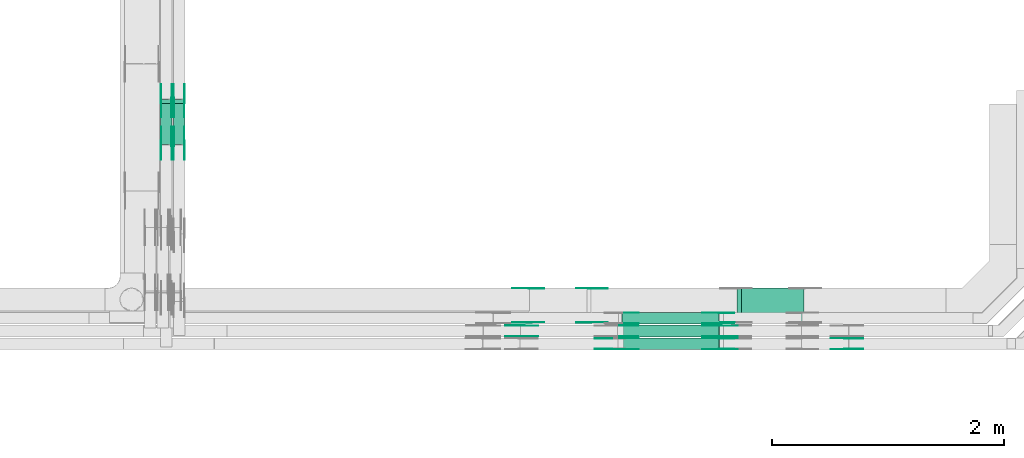
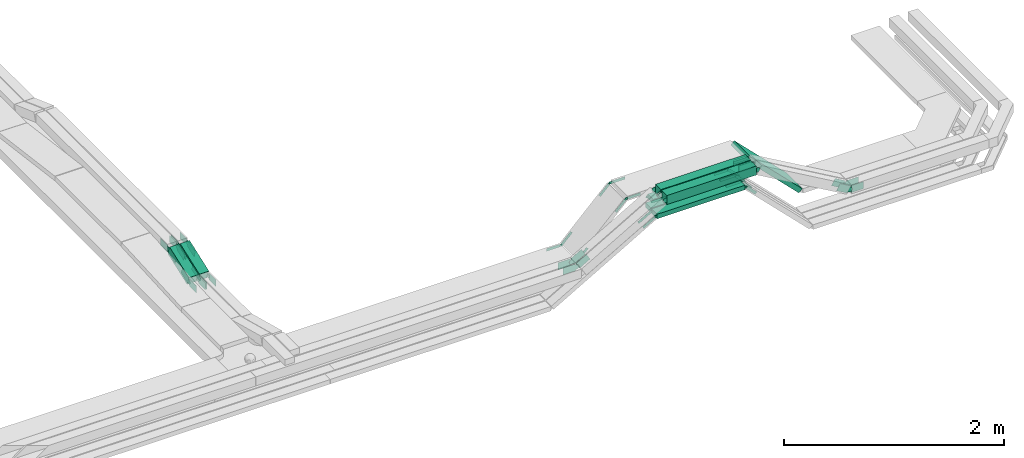
# One storey, part 26 of 32: 58 flow fittings, 8 flow segments.
"""IFC2X3 building model written with IfcOpenShell, lengths in millimetres."""

from ifc_helpers import new_model, entity, si_unit, converted_unit, derived_unit, direction, frame, frame_2d, origin, origin_2d_with_axis, place, context, subcontext, project, spatial, polyline, circle_curve, parameter, trimmed, segment, composite_curve, rectangle, outline, extrude, source, transform, mapped, material, type_object, type_shapes, element, save


model = new_model("IFC2X3")

# Units and contexts
model_context = context("Model", 3, precision=0.01, world=origin(), true_north=direction((6.12303176911189e-17, 1.0)))
body_context = subcontext(model_context, "Body", "Model", "MODEL_VIEW")
ifc_project = project(units=[si_unit("LENGTHUNIT", "METRE", prefix="MILLI"), si_unit("AREAUNIT", "SQUARE_METRE"), si_unit("VOLUMEUNIT", "CUBIC_METRE"), converted_unit("PLANEANGLEUNIT", "DEGREE", entity("IfcRatioMeasure", 0.0174532925199433), si_unit("PLANEANGLEUNIT", "RADIAN"), dimensions=[0, 0, 0, 0, 0, 0, 0]), si_unit("MASSUNIT", "GRAM", prefix="KILO"), derived_unit("MASSDENSITYUNIT", [(si_unit("MASSUNIT", "GRAM", prefix="KILO"), 1), (si_unit("LENGTHUNIT", "METRE"), -3)]), derived_unit("MOMENTOFINERTIAUNIT", [(si_unit("LENGTHUNIT", "METRE"), 4)]), si_unit("TIMEUNIT", "SECOND"), si_unit("FREQUENCYUNIT", "HERTZ"), si_unit("THERMODYNAMICTEMPERATUREUNIT", "DEGREE_CELSIUS"), derived_unit("THERMALTRANSMITTANCEUNIT", [(si_unit("MASSUNIT", "GRAM", prefix="KILO"), 1), (si_unit("THERMODYNAMICTEMPERATUREUNIT", "KELVIN"), -1), (si_unit("TIMEUNIT", "SECOND"), -3)]), derived_unit("VOLUMETRICFLOWRATEUNIT", [(si_unit("LENGTHUNIT", "METRE"), 3), (si_unit("TIMEUNIT", "SECOND"), -1)]), derived_unit("MASSFLOWRATEUNIT", [(si_unit("MASSUNIT", "GRAM", prefix="KILO"), 1), (si_unit("TIMEUNIT", "SECOND"), -1)]), derived_unit("ROTATIONALFREQUENCYUNIT", [(si_unit("TIMEUNIT", "SECOND"), -1)]), si_unit("ELECTRICCURRENTUNIT", "AMPERE"), si_unit("ELECTRICVOLTAGEUNIT", "VOLT"), si_unit("POWERUNIT", "WATT"), si_unit("FORCEUNIT", "NEWTON", prefix="KILO"), si_unit("ILLUMINANCEUNIT", "LUX"), si_unit("LUMINOUSFLUXUNIT", "LUMEN"), si_unit("LUMINOUSINTENSITYUNIT", "CANDELA"), derived_unit("USERDEFINED", [(si_unit("MASSUNIT", "GRAM", prefix="KILO"), -1), (si_unit("LENGTHUNIT", "METRE"), -2), (si_unit("TIMEUNIT", "SECOND"), 3), (si_unit("LUMINOUSFLUXUNIT", "LUMEN"), 1)]), derived_unit("LINEARVELOCITYUNIT", [(si_unit("LENGTHUNIT", "METRE"), 1), (si_unit("TIMEUNIT", "SECOND"), -1)]), si_unit("PRESSUREUNIT", "PASCAL"), derived_unit("USERDEFINED", [(si_unit("LENGTHUNIT", "METRE"), -2), (si_unit("MASSUNIT", "GRAM", prefix="KILO"), 1), (si_unit("TIMEUNIT", "SECOND"), -2)]), derived_unit("LINEARFORCEUNIT", [(si_unit("MASSUNIT", "GRAM", prefix="KILO"), 1), (si_unit("LENGTHUNIT", "METRE"), 1), (si_unit("TIMEUNIT", "SECOND"), -2), (si_unit("LENGTHUNIT", "METRE"), -1)]), derived_unit("PLANARFORCEUNIT", [(si_unit("MASSUNIT", "GRAM", prefix="KILO"), 1), (si_unit("LENGTHUNIT", "METRE"), 1), (si_unit("TIMEUNIT", "SECOND"), -2), (si_unit("LENGTHUNIT", "METRE"), -2)])], contexts=[model_context])

# Site, building, storey
site_placement = place(None, origin())
site = spatial("IfcSite", under=ifc_project, at=site_placement, CompositionType="ELEMENT")
building_placement = place(site_placement, origin())
building = spatial("IfcBuilding", under=site, at=building_placement, CompositionType="ELEMENT")
storey_placement = place(building_placement, frame((0.0, 0.0, 8100.0)))
storey = spatial("IfcBuildingStorey", under=building, at=storey_placement, CompositionType="ELEMENT", Elevation=8100.0)

# Flow segments
cable_carrier_segment_type = type_object("IfcCableCarrierSegmentType", PredefinedType="CABLETRAYSEGMENT")
flow_segment_1_placement = place(storey_placement, frame((64598.66, 8749.98, 3299.35)))
element("IfcFlowSegment", 1, at=flow_segment_1_placement, inside=storey, type_object=cable_carrier_segment_type, context=body_context, shape_type="SweptSolid", body=[
    extrude(rectangle(XDim=939.968624882914, YDim=99.9999999999989, at=origin_2d_with_axis()), frame((469.98, 50.0, 0.0)), (0.0, 0.0, 1.0), 99.9999999999989),
])
flow_segment_2_placement = place(storey_placement, frame((65573.52, 8869.98, 2758.52)))
element("IfcFlowSegment", 2, at=flow_segment_2_placement, inside=storey, type_object=cable_carrier_segment_type, context=body_context, shape_type="SweptSolid", body=[
    extrude(rectangle(XDim=49.9999999999911, YDim=299.999999999999, at=frame_2d((0.0, 0.0), x_axis=(0.0, 1.0))), frame((17.68, 150.0, 559.42), z_axis=(0.707106781186569, 0.0, -0.707106781186526), x_axis=(0.0, 1.0, 0.0)), (0.0, 0.0, 1.0), 766.14487381345),
])
flow_segment_3_placement = place(storey_placement, frame((64600.05, 8639.98, 3300.15)))
element("IfcFlowSegment", 3, at=flow_segment_3_placement, inside=storey, type_object=cable_carrier_segment_type, context=body_context, shape_type="SweptSolid", body=[
    extrude(rectangle(XDim=937.197353006379, YDim=100.000000000001, at=origin_2d_with_axis()), frame((468.6, 50.0, 0.0), z_axis=(0.0, 0.0, 1.0), x_axis=(-1.0, 0.0, 0.0)), (0.0, 0.0, 1.0), 99.9999999999989),
])
flow_segment_4_placement = place(storey_placement, frame((64494.58, 8639.98, 3179.57)))
element("IfcFlowSegment", 4, at=flow_segment_4_placement, inside=storey, type_object=cable_carrier_segment_type, context=body_context, shape_type="SweptSolid", body=[
    extrude(rectangle(XDim=920.492323280355, YDim=99.9999999979415, at=origin_2d_with_axis()), frame((460.25, 50.0, 0.0), z_axis=(-6.41725804195765e-06, 0.0, 1.0), x_axis=(-1.0, 0.0, -6.41725804195765e-06)), (0.0, 0.0, 1.0), 49.9999999989737),
])
flow_segment_5_placement = place(storey_placement, frame((64494.58, 8749.98, 3179.57)))
element("IfcFlowSegment", 5, at=flow_segment_5_placement, inside=storey, type_object=cable_carrier_segment_type, context=body_context, shape_type="SweptSolid", body=[
    extrude(rectangle(XDim=920.463298114925, YDim=99.9999999758575, at=origin_2d_with_axis()), frame((460.23, 50.0, 0.01), z_axis=(-3.05650475309181e-05, 0.0, 1.0), x_axis=(-1.0, 0.0, -3.05650475309181e-05)), (0.0, 0.0, 1.0), 49.9999999879301),
])
flow_segment_6_placement = place(storey_placement, frame((64581.24, 8859.98, 3179.57)))
element("IfcFlowSegment", 6, at=flow_segment_6_placement, inside=storey, type_object=cable_carrier_segment_type, context=body_context, shape_type="SweptSolid", body=[
    extrude(rectangle(XDim=833.83326858157, YDim=100.000000000001, at=origin_2d_with_axis()), frame((416.92, 50.0, 0.0), z_axis=(0.0, 0.0, 1.0), x_axis=(-1.0, 0.0, 0.0)), (0.0, 0.0, 1.0), 50.0000000000016),
])
flow_segment_7_placement = place(storey_placement, frame((60610.11, 10406.15, 2721.68)))
element("IfcFlowSegment", 7, at=flow_segment_7_placement, inside=storey, type_object=cable_carrier_segment_type, context=body_context, shape_type="SweptSolid", body=[
    extrude(rectangle(XDim=100.000000000001, YDim=99.9999999999946, at=origin_2d_with_axis()), frame((50.0, 17.1, 46.98), z_axis=(0.0, 0.939692620785929, 0.342020143325613), x_axis=(0.0, -0.342020143325613, 0.939692620785929)), (0.0, 0.0, 1.0), 373.670280105796),
])
flow_segment_8_placement = place(storey_placement, frame((60720.11, 10406.13, 2721.71)))
element("IfcFlowSegment", 8, at=flow_segment_8_placement, inside=storey, type_object=cable_carrier_segment_type, context=body_context, shape_type="SweptSolid", body=[
    extrude(rectangle(XDim=99.9999999999992, YDim=99.9999999999946, at=origin_2d_with_axis()), frame((50.0, 17.1, 46.98), z_axis=(0.0, 0.939692620787677, 0.34202014332081), x_axis=(0.0, -0.34202014332081, 0.939692620787677)), (0.0, 0.0, 1.0), 373.682611233208),
])

# Flow fittings
ifc_material = material(Name="G")
cable_carrier_fitting_type_1 = type_object("IfcCableCarrierFittingType", PredefinedType="NOTDEFINED", material=ifc_material)
shared_shape_1 = source(origin(), body_context, "Body", "SweptSolid", [
    extrude(outline(composite_curve([segment(trimmed(circle_curve(frame_2d((-44.59, 0.0), x_axis=(1.0, 0.0)), 12.5), [parameter(90.0000000000007)], [parameter(270.0)], True, "PARAMETER"), True, "CONTINUOUS"), segment(polyline([(-44.59, -12.5), (-33.09, -12.5)]), True, "CONTINUOUS"), segment(polyline([(-33.09, -12.5), (-31.23, -14.5)]), True, "CONTINUOUS"), segment(polyline([(-31.23, -14.5), (108.91, -14.5)]), True, "CONTINUOUS"), segment(polyline([(108.91, -14.5), (108.91, 14.5)]), True, "CONTINUOUS"), segment(polyline([(108.91, 14.5), (-31.23, 14.5)]), True, "CONTINUOUS"), segment(polyline([(-31.23, 14.5), (-33.09, 12.5)]), True, "CONTINUOUS"), segment(polyline([(-33.09, 12.5), (-44.59, 12.5)]), True, "CONTINUOUS")], self_intersect=False)), frame((44.59, 0.0, 0.0), z_axis=(0.0, 0.0, -1.0), x_axis=(1.0, 0.0, 0.0)), (0.0, 0.0, -1.0), 2.0),
])
type_shapes(cable_carrier_fitting_type_1, [shared_shape_1])
flow_fitting_1_placement = place(storey_placement, frame((65428.08, 8864.52, 3204.57), z_axis=(0.0, -1.0, 0.0), x_axis=(-1.0, 0.0, 0.0)))
element("IfcFlowFitting", 9, at=flow_fitting_1_placement, inside=storey, type_object=cable_carrier_fitting_type_1, material=ifc_material, context=body_context, shape_type="MappedRepresentation", body=[
    mapped(shared_shape_1, transform((0.0, 0.0, 0.0), scale=1.0)),
])
cable_carrier_fitting_type_2 = type_object("IfcCableCarrierFittingType", PredefinedType="NOTDEFINED", material=ifc_material)
type_shapes(cable_carrier_fitting_type_2, [shared_shape_1])
flow_fitting_2_placement = place(storey_placement, frame((65428.08, 8953.44, 3204.57), z_axis=(0.0, 1.0, 0.0), x_axis=(0.707106781186533, 0.0, -0.707106781186562)))
element("IfcFlowFitting", 10, at=flow_fitting_2_placement, inside=storey, type_object=cable_carrier_fitting_type_2, material=ifc_material, context=body_context, shape_type="MappedRepresentation", body=[
    mapped(shared_shape_1, transform((0.0, 0.0, 0.0), scale=1.0)),
])
for number, where, z_axis, x_axis in (
    (11, (64572.47, 8955.44, 3204.57), (0.0, 1.0, 0.0), (1.0, 0.0, 0.0)),
    (12, (65428.06, 8754.52, 3204.6), (0.0, -1.0, 0.0), (-0.999999977631966, 0.0, -0.000211509025242751)),
):
    element("IfcFlowFitting", number, at=place(storey_placement, frame(where, z_axis=z_axis, x_axis=x_axis)), inside=storey, type_object=cable_carrier_fitting_type_1, material=ifc_material, context=body_context, shape_type="MappedRepresentation", body=[
        mapped(shared_shape_1, transform((0.0, 0.0, 0.0), scale=1.0)),
    ])
flow_fitting_3_placement = place(storey_placement, frame((65428.06, 8843.44, 3204.6), z_axis=(0.0, 1.0, 0.0), x_axis=(0.707106781186527, 0.0, -0.707106781186568)))
element("IfcFlowFitting", 13, at=flow_fitting_3_placement, inside=storey, type_object=cable_carrier_fitting_type_2, material=ifc_material, context=body_context, shape_type="MappedRepresentation", body=[
    mapped(shared_shape_1, transform((0.0, 0.0, 0.0), scale=1.0)),
])
flow_fitting_4_placement = place(storey_placement, frame((65428.08, 8644.52, 3204.57), z_axis=(0.0, -1.0, 0.0), x_axis=(-1.0, 0.0, -2.81226541815616e-05)))
element("IfcFlowFitting", 14, at=flow_fitting_4_placement, inside=storey, type_object=cable_carrier_fitting_type_1, material=ifc_material, context=body_context, shape_type="MappedRepresentation", body=[
    mapped(shared_shape_1, transform((0.0, 0.0, 0.0), scale=1.0)),
])
for number, where, z_axis, x_axis in (
    (15, (65428.08, 8733.44, 3204.57), (0.0, 1.0, 0.0), (0.707106781186496, 0.0, -0.707106781186599)),
    (16, (64485.81, 8646.52, 3204.57), (0.0, -1.0, 0.0), (-0.866025403784408, 0.0, -0.500000000000054)),
):
    element("IfcFlowFitting", number, at=place(storey_placement, frame(where, z_axis=z_axis, x_axis=x_axis)), inside=storey, type_object=cable_carrier_fitting_type_2, material=ifc_material, context=body_context, shape_type="MappedRepresentation", body=[
        mapped(shared_shape_1, transform((0.0, 0.0, 0.0), scale=1.0)),
    ])
flow_fitting_5_placement = place(storey_placement, frame((64306.08, 8874.52, 3327.15), z_axis=(0.0, -1.0, 0.0), x_axis=(-0.707106781186591, 0.0, -0.707106781186504)))
element("IfcFlowFitting", 17, at=flow_fitting_5_placement, inside=storey, type_object=cable_carrier_fitting_type_1, material=ifc_material, context=body_context, shape_type="MappedRepresentation", body=[
    mapped(shared_shape_1, transform((0.0, 0.0, 0.0), scale=1.0)),
])
for number, where, z_axis, x_axis in (
    (18, (64306.08, 9163.44, 3327.15), (0.0, 1.0, 0.0), (1.0, 0.0, 0.0)),
    (19, (65581.99, 8876.52, 3327.15), (0.0, -1.0, 0.0), (-1.0, 0.0, 0.0)),
):
    element("IfcFlowFitting", number, at=place(storey_placement, frame(where, z_axis=z_axis, x_axis=x_axis)), inside=storey, type_object=cable_carrier_fitting_type_2, material=ifc_material, context=body_context, shape_type="MappedRepresentation", body=[
        mapped(shared_shape_1, transform((0.0, 0.0, 0.0), scale=1.0)),
    ])
flow_fitting_6_placement = place(storey_placement, frame((63792.86, 9165.44, 2813.92), z_axis=(0.0, 1.0, 0.0), x_axis=(-1.0, 0.0, 0.0)))
element("IfcFlowFitting", 20, at=flow_fitting_6_placement, inside=storey, type_object=cable_carrier_fitting_type_1, material=ifc_material, context=body_context, shape_type="MappedRepresentation", body=[
    mapped(shared_shape_1, transform((0.0, 0.0, 0.0), scale=1.0)),
])
flow_fitting_7_placement = place(storey_placement, frame((63792.86, 8876.52, 2813.92), z_axis=(0.0, -1.0, 0.0), x_axis=(0.70710678118647, 0.0, 0.707106781186625)))
element("IfcFlowFitting", 21, at=flow_fitting_7_placement, inside=storey, type_object=cable_carrier_fitting_type_2, material=ifc_material, context=body_context, shape_type="MappedRepresentation", body=[
    mapped(shared_shape_1, transform((0.0, 0.0, 0.0), scale=1.0)),
])
cable_carrier_fitting_type_3 = type_object("IfcCableCarrierFittingType", PredefinedType="NOTDEFINED", material=ifc_material)
shared_shape_2 = source(origin(), body_context, "Body", "SweptSolid", [
    extrude(outline(composite_curve([segment(trimmed(circle_curve(frame_2d((-44.59, 0.0), x_axis=(1.0, 0.0)), 12.5), [parameter(90.0000000000007)], [parameter(270.0)], True, "PARAMETER"), True, "CONTINUOUS"), segment(polyline([(-44.59, -12.5), (-33.09, -12.5)]), True, "CONTINUOUS"), segment(polyline([(-33.09, -12.5), (-31.23, -14.5)]), True, "CONTINUOUS"), segment(polyline([(-31.23, -14.5), (108.91, -14.5)]), True, "CONTINUOUS"), segment(polyline([(108.91, -14.5), (108.91, 14.5)]), True, "CONTINUOUS"), segment(polyline([(108.91, 14.5), (-31.23, 14.5)]), True, "CONTINUOUS"), segment(polyline([(-31.23, 14.5), (-33.09, 12.5)]), True, "CONTINUOUS"), segment(polyline([(-33.09, 12.5), (-44.59, 12.5)]), True, "CONTINUOUS")], self_intersect=False)), frame((44.59, 0.0, 0.0)), (0.0, 0.0, 1.0), 2.0),
])
type_shapes(cable_carrier_fitting_type_3, [shared_shape_2])
flow_fitting_8_placement = place(storey_placement, frame((65428.08, 8955.44, 3204.57), z_axis=(0.0, 1.0, 0.0), x_axis=(-1.0, 0.0, 0.0)))
element("IfcFlowFitting", 22, at=flow_fitting_8_placement, inside=storey, type_object=cable_carrier_fitting_type_3, material=ifc_material, context=body_context, shape_type="MappedRepresentation", body=[
    mapped(shared_shape_2, transform((0.0, 0.0, 0.0), scale=1.0)),
])
cable_carrier_fitting_type_4 = type_object("IfcCableCarrierFittingType", PredefinedType="NOTDEFINED", material=ifc_material)
type_shapes(cable_carrier_fitting_type_4, [shared_shape_2])
flow_fitting_9_placement = place(storey_placement, frame((65428.08, 8866.52, 3204.57), z_axis=(0.0, -1.0, 0.0), x_axis=(0.707106781186533, 0.0, -0.707106781186562)))
element("IfcFlowFitting", 23, at=flow_fitting_9_placement, inside=storey, type_object=cable_carrier_fitting_type_4, material=ifc_material, context=body_context, shape_type="MappedRepresentation", body=[
    mapped(shared_shape_2, transform((0.0, 0.0, 0.0), scale=1.0)),
])
for number, where, z_axis, x_axis in (
    (24, (64572.47, 8864.52, 3204.57), (0.0, -1.0, 0.0), (1.0, 0.0, 0.0)),
    (25, (65428.06, 8845.44, 3204.6), (0.0, 1.0, 0.0), (-0.999999977631966, 0.0, -0.000211509025242751)),
):
    element("IfcFlowFitting", number, at=place(storey_placement, frame(where, z_axis=z_axis, x_axis=x_axis)), inside=storey, type_object=cable_carrier_fitting_type_3, material=ifc_material, context=body_context, shape_type="MappedRepresentation", body=[
        mapped(shared_shape_2, transform((0.0, 0.0, 0.0), scale=1.0)),
    ])
flow_fitting_10_placement = place(storey_placement, frame((65428.06, 8756.52, 3204.6), z_axis=(0.0, -1.0, 0.0), x_axis=(0.707106781186527, 0.0, -0.707106781186568)))
element("IfcFlowFitting", 26, at=flow_fitting_10_placement, inside=storey, type_object=cable_carrier_fitting_type_4, material=ifc_material, context=body_context, shape_type="MappedRepresentation", body=[
    mapped(shared_shape_2, transform((0.0, 0.0, 0.0), scale=1.0)),
])
flow_fitting_11_placement = place(storey_placement, frame((65428.08, 8735.44, 3204.57), z_axis=(0.0, 1.0, 0.0), x_axis=(-1.0, 0.0, -2.81226541815616e-05)))
element("IfcFlowFitting", 27, at=flow_fitting_11_placement, inside=storey, type_object=cable_carrier_fitting_type_3, material=ifc_material, context=body_context, shape_type="MappedRepresentation", body=[
    mapped(shared_shape_2, transform((0.0, 0.0, 0.0), scale=1.0)),
])
flow_fitting_12_placement = place(storey_placement, frame((65428.08, 8646.52, 3204.57), z_axis=(0.0, -1.0, 0.0), x_axis=(0.707106781186496, 0.0, -0.707106781186599)))
element("IfcFlowFitting", 28, at=flow_fitting_12_placement, inside=storey, type_object=cable_carrier_fitting_type_4, material=ifc_material, context=body_context, shape_type="MappedRepresentation", body=[
    mapped(shared_shape_2, transform((0.0, 0.0, 0.0), scale=1.0)),
])
flow_fitting_13_placement = place(storey_placement, frame((64485.81, 8644.52, 3204.57), z_axis=(0.0, -1.0, 0.0), x_axis=(1.0, 0.0, 9.05365043246675e-06)))
element("IfcFlowFitting", 29, at=flow_fitting_13_placement, inside=storey, type_object=cable_carrier_fitting_type_3, material=ifc_material, context=body_context, shape_type="MappedRepresentation", body=[
    mapped(shared_shape_2, transform((0.0, 0.0, 0.0), scale=1.0)),
])
flow_fitting_14_placement = place(storey_placement, frame((64485.81, 8733.44, 3204.57), z_axis=(0.0, 1.0, 0.0), x_axis=(-0.866025403784408, 0.0, -0.500000000000054)))
element("IfcFlowFitting", 30, at=flow_fitting_14_placement, inside=storey, type_object=cable_carrier_fitting_type_4, material=ifc_material, context=body_context, shape_type="MappedRepresentation", body=[
    mapped(shared_shape_2, transform((0.0, 0.0, 0.0), scale=1.0)),
])
flow_fitting_15_placement = place(storey_placement, frame((64306.08, 9165.44, 3327.15), z_axis=(0.0, 1.0, 0.0), x_axis=(-0.707106781186591, 0.0, -0.707106781186504)))
element("IfcFlowFitting", 31, at=flow_fitting_15_placement, inside=storey, type_object=cable_carrier_fitting_type_3, material=ifc_material, context=body_context, shape_type="MappedRepresentation", body=[
    mapped(shared_shape_2, transform((0.0, 0.0, 0.0), scale=1.0)),
])
flow_fitting_16_placement = place(storey_placement, frame((64306.08, 8876.52, 3327.15), z_axis=(0.0, -1.0, 0.0), x_axis=(1.0, 0.0, 0.0)))
element("IfcFlowFitting", 32, at=flow_fitting_16_placement, inside=storey, type_object=cable_carrier_fitting_type_4, material=ifc_material, context=body_context, shape_type="MappedRepresentation", body=[
    mapped(shared_shape_2, transform((0.0, 0.0, 0.0), scale=1.0)),
])
flow_fitting_17_placement = place(storey_placement, frame((63792.86, 8874.52, 2813.92), z_axis=(0.0, -1.0, 0.0), x_axis=(-1.0, 0.0, 0.0)))
element("IfcFlowFitting", 33, at=flow_fitting_17_placement, inside=storey, type_object=cable_carrier_fitting_type_3, material=ifc_material, context=body_context, shape_type="MappedRepresentation", body=[
    mapped(shared_shape_2, transform((0.0, 0.0, 0.0), scale=1.0)),
])
flow_fitting_18_placement = place(storey_placement, frame((63792.86, 9163.44, 2813.92), z_axis=(0.0, 1.0, 0.0), x_axis=(0.70710678118647, 0.0, 0.707106781186625)))
element("IfcFlowFitting", 34, at=flow_fitting_18_placement, inside=storey, type_object=cable_carrier_fitting_type_4, material=ifc_material, context=body_context, shape_type="MappedRepresentation", body=[
    mapped(shared_shape_2, transform((0.0, 0.0, 0.0), scale=1.0)),
])
cable_carrier_fitting_type_5 = type_object("IfcCableCarrierFittingType", PredefinedType="NOTDEFINED", material=ifc_material)
shared_shape_3 = source(origin(), body_context, "Body", "SweptSolid", [
    extrude(outline(composite_curve([segment(trimmed(circle_curve(frame_2d((-41.47, 0.0), x_axis=(1.0, 0.0)), 25.0), [parameter(90.0000000000007)], [parameter(270.0)], True, "PARAMETER"), True, "CONTINUOUS"), segment(polyline([(-41.47, -25.0), (-29.97, -25.0)]), True, "CONTINUOUS"), segment(polyline([(-29.97, -25.0), (-28.1, -38.5)]), True, "CONTINUOUS"), segment(polyline([(-28.1, -38.5), (99.53, -38.5)]), True, "CONTINUOUS"), segment(polyline([(99.53, -38.5), (99.53, 38.5)]), True, "CONTINUOUS"), segment(polyline([(99.53, 38.5), (-28.1, 38.5)]), True, "CONTINUOUS"), segment(polyline([(-28.1, 38.5), (-29.97, 25.0)]), True, "CONTINUOUS"), segment(polyline([(-29.97, 25.0), (-41.47, 25.0)]), True, "CONTINUOUS")], self_intersect=False)), frame((41.47, 0.0, 0.0), z_axis=(0.0, 0.0, -1.0), x_axis=(1.0, 0.0, 0.0)), (0.0, 0.0, -1.0), 2.0),
])
type_shapes(cable_carrier_fitting_type_5, [shared_shape_3])
flow_fitting_19_placement = place(storey_placement, frame((60614.65, 10784.27, 2900.06), z_axis=(-1.0, 0.0, 0.0), x_axis=(0.0, 1.0, 0.0)))
element("IfcFlowFitting", 35, at=flow_fitting_19_placement, inside=storey, type_object=cable_carrier_fitting_type_5, material=ifc_material, context=body_context, shape_type="MappedRepresentation", body=[
    mapped(shared_shape_3, transform((0.0, 0.0, 0.0), scale=1.0)),
])
cable_carrier_fitting_type_6 = type_object("IfcCableCarrierFittingType", PredefinedType="NOTDEFINED", material=ifc_material)
type_shapes(cable_carrier_fitting_type_6, [shared_shape_3])
flow_fitting_20_placement = place(storey_placement, frame((60703.57, 10784.27, 2900.06), z_axis=(1.0, 0.0, 0.0), x_axis=(0.0, -0.939692620785937, -0.342020143325589)))
element("IfcFlowFitting", 36, at=flow_fitting_20_placement, inside=storey, type_object=cable_carrier_fitting_type_6, material=ifc_material, context=body_context, shape_type="MappedRepresentation", body=[
    mapped(shared_shape_3, transform((0.0, 0.0, 0.0), scale=1.0)),
])
flow_fitting_21_placement = place(storey_placement, frame((60614.65, 10413.36, 2765.06), z_axis=(-1.0, 0.0, 0.0), x_axis=(0.0, -1.0, 0.0)))
element("IfcFlowFitting", 37, at=flow_fitting_21_placement, inside=storey, type_object=cable_carrier_fitting_type_5, material=ifc_material, context=body_context, shape_type="MappedRepresentation", body=[
    mapped(shared_shape_3, transform((0.0, 0.0, 0.0), scale=1.0)),
])
flow_fitting_22_placement = place(storey_placement, frame((60703.57, 10413.36, 2765.06), z_axis=(1.0, 0.0, 0.0), x_axis=(0.0, 0.93969262078593, 0.34202014332561)))
element("IfcFlowFitting", 38, at=flow_fitting_22_placement, inside=storey, type_object=cable_carrier_fitting_type_6, material=ifc_material, context=body_context, shape_type="MappedRepresentation", body=[
    mapped(shared_shape_3, transform((0.0, 0.0, 0.0), scale=1.0)),
])
flow_fitting_23_placement = place(storey_placement, frame((60724.65, 10784.27, 2900.1), z_axis=(-1.0, 0.0, 0.0), x_axis=(0.0, 1.0, 0.0)))
element("IfcFlowFitting", 39, at=flow_fitting_23_placement, inside=storey, type_object=cable_carrier_fitting_type_5, material=ifc_material, context=body_context, shape_type="MappedRepresentation", body=[
    mapped(shared_shape_3, transform((0.0, 0.0, 0.0), scale=1.0)),
])
flow_fitting_24_placement = place(storey_placement, frame((60813.57, 10784.27, 2900.1), z_axis=(1.0, 0.0, 0.0), x_axis=(0.0, -0.939692620787653, -0.342020143320874)))
element("IfcFlowFitting", 40, at=flow_fitting_24_placement, inside=storey, type_object=cable_carrier_fitting_type_6, material=ifc_material, context=body_context, shape_type="MappedRepresentation", body=[
    mapped(shared_shape_3, transform((0.0, 0.0, 0.0), scale=1.0)),
])
flow_fitting_25_placement = place(storey_placement, frame((60724.65, 10413.35, 2765.1), z_axis=(-1.0, 0.0, 0.0), x_axis=(0.0, -1.0, 5.41816061694345e-06)))
element("IfcFlowFitting", 41, at=flow_fitting_25_placement, inside=storey, type_object=cable_carrier_fitting_type_5, material=ifc_material, context=body_context, shape_type="MappedRepresentation", body=[
    mapped(shared_shape_3, transform((0.0, 0.0, 0.0), scale=1.0)),
])
flow_fitting_26_placement = place(storey_placement, frame((60813.57, 10413.35, 2765.1), z_axis=(1.0, 0.0, 0.0), x_axis=(0.0, 0.939692620787683, 0.342020143320792)))
element("IfcFlowFitting", 42, at=flow_fitting_26_placement, inside=storey, type_object=cable_carrier_fitting_type_6, material=ifc_material, context=body_context, shape_type="MappedRepresentation", body=[
    mapped(shared_shape_3, transform((0.0, 0.0, 0.0), scale=1.0)),
])
flow_fitting_27_placement = place(storey_placement, frame((66519.46, 8735.44, 2792.0), z_axis=(0.0, 1.0, 0.0), x_axis=(-0.866025403786882, 0.0, 0.499999999995767)))
element("IfcFlowFitting", 43, at=flow_fitting_27_placement, inside=storey, type_object=cable_carrier_fitting_type_5, material=ifc_material, context=body_context, shape_type="MappedRepresentation", body=[
    mapped(shared_shape_3, transform((0.0, 0.0, 0.0), scale=1.0)),
])
for number, where, z_axis, x_axis in (
    (44, (66519.46, 8646.52, 2792.0), (0.0, -1.0, 0.0), (1.0, 0.0, 0.0)),
    (45, (64583.19, 8843.44, 3349.35), (0.0, 1.0, 0.0), (1.0, 0.0, 0.0)),
    (46, (65554.1, 8756.52, 3349.35), (0.0, -1.0, 0.0), (-1.0, 0.0, 0.0)),
):
    element("IfcFlowFitting", number, at=place(storey_placement, frame(where, z_axis=z_axis, x_axis=x_axis)), inside=storey, type_object=cable_carrier_fitting_type_6, material=ifc_material, context=body_context, shape_type="MappedRepresentation", body=[
        mapped(shared_shape_3, transform((0.0, 0.0, 0.0), scale=1.0)),
    ])
for number, where, z_axis, x_axis in (
    (47, (65552.72, 8644.52, 3350.15), (0.0, -1.0, 0.0), (-1.0, 0.0, 0.0)),
    (48, (64584.58, 8735.44, 3350.15), (0.0, 1.0, 0.0), (1.0, 0.0, 0.0)),
    (49, (63718.32, 8845.44, 2850.01), (0.0, 1.0, 0.0), (-1.0, 0.0, 8.83735248702333e-07)),
):
    element("IfcFlowFitting", number, at=place(storey_placement, frame(where, z_axis=z_axis, x_axis=x_axis)), inside=storey, type_object=cable_carrier_fitting_type_5, material=ifc_material, context=body_context, shape_type="MappedRepresentation", body=[
        mapped(shared_shape_3, transform((0.0, 0.0, 0.0), scale=1.0)),
    ])
flow_fitting_28_placement = place(storey_placement, frame((63718.32, 8756.52, 2850.01), z_axis=(0.0, -1.0, 0.0), x_axis=(0.866025403784432, 0.0, 0.500000000000012)))
element("IfcFlowFitting", 50, at=flow_fitting_28_placement, inside=storey, type_object=cable_carrier_fitting_type_6, material=ifc_material, context=body_context, shape_type="MappedRepresentation", body=[
    mapped(shared_shape_3, transform((0.0, 0.0, 0.0), scale=1.0)),
])
cable_carrier_fitting_type_7 = type_object("IfcCableCarrierFittingType", PredefinedType="NOTDEFINED", material=ifc_material)
shared_shape_4 = source(origin(), body_context, "Body", "SweptSolid", [
    extrude(outline(composite_curve([segment(trimmed(circle_curve(frame_2d((-41.47, 0.0), x_axis=(1.0, 0.0)), 25.0), [parameter(90.0000000000007)], [parameter(270.0)], True, "PARAMETER"), True, "CONTINUOUS"), segment(polyline([(-41.47, -25.0), (-29.97, -25.0)]), True, "CONTINUOUS"), segment(polyline([(-29.97, -25.0), (-28.1, -38.5)]), True, "CONTINUOUS"), segment(polyline([(-28.1, -38.5), (99.53, -38.5)]), True, "CONTINUOUS"), segment(polyline([(99.53, -38.5), (99.53, 38.5)]), True, "CONTINUOUS"), segment(polyline([(99.53, 38.5), (-28.1, 38.5)]), True, "CONTINUOUS"), segment(polyline([(-28.1, 38.5), (-29.97, 25.0)]), True, "CONTINUOUS"), segment(polyline([(-29.97, 25.0), (-41.47, 25.0)]), True, "CONTINUOUS")], self_intersect=False)), frame((41.47, 0.0, 0.0)), (0.0, 0.0, 1.0), 2.0),
])
type_shapes(cable_carrier_fitting_type_7, [shared_shape_4])
flow_fitting_29_placement = place(storey_placement, frame((60705.57, 10784.27, 2900.06), z_axis=(1.0, 0.0, 0.0), x_axis=(0.0, 1.0, 0.0)))
element("IfcFlowFitting", 51, at=flow_fitting_29_placement, inside=storey, type_object=cable_carrier_fitting_type_7, material=ifc_material, context=body_context, shape_type="MappedRepresentation", body=[
    mapped(shared_shape_4, transform((0.0, 0.0, 0.0), scale=1.0)),
])
cable_carrier_fitting_type_8 = type_object("IfcCableCarrierFittingType", PredefinedType="NOTDEFINED", material=ifc_material)
type_shapes(cable_carrier_fitting_type_8, [shared_shape_4])
flow_fitting_30_placement = place(storey_placement, frame((60616.65, 10784.27, 2900.06), z_axis=(-1.0, 0.0, 0.0), x_axis=(0.0, -0.939692620785937, -0.342020143325589)))
element("IfcFlowFitting", 52, at=flow_fitting_30_placement, inside=storey, type_object=cable_carrier_fitting_type_8, material=ifc_material, context=body_context, shape_type="MappedRepresentation", body=[
    mapped(shared_shape_4, transform((0.0, 0.0, 0.0), scale=1.0)),
])
flow_fitting_31_placement = place(storey_placement, frame((60705.57, 10413.36, 2765.06), z_axis=(1.0, 0.0, 0.0), x_axis=(0.0, -1.0, 0.0)))
element("IfcFlowFitting", 53, at=flow_fitting_31_placement, inside=storey, type_object=cable_carrier_fitting_type_7, material=ifc_material, context=body_context, shape_type="MappedRepresentation", body=[
    mapped(shared_shape_4, transform((0.0, 0.0, 0.0), scale=1.0)),
])
flow_fitting_32_placement = place(storey_placement, frame((60616.65, 10413.36, 2765.06), z_axis=(-1.0, 0.0, 0.0), x_axis=(0.0, 0.93969262078593, 0.34202014332561)))
element("IfcFlowFitting", 54, at=flow_fitting_32_placement, inside=storey, type_object=cable_carrier_fitting_type_8, material=ifc_material, context=body_context, shape_type="MappedRepresentation", body=[
    mapped(shared_shape_4, transform((0.0, 0.0, 0.0), scale=1.0)),
])
flow_fitting_33_placement = place(storey_placement, frame((60815.57, 10784.27, 2900.1), z_axis=(1.0, 0.0, 0.0), x_axis=(0.0, 1.0, 0.0)))
element("IfcFlowFitting", 55, at=flow_fitting_33_placement, inside=storey, type_object=cable_carrier_fitting_type_7, material=ifc_material, context=body_context, shape_type="MappedRepresentation", body=[
    mapped(shared_shape_4, transform((0.0, 0.0, 0.0), scale=1.0)),
])
flow_fitting_34_placement = place(storey_placement, frame((60726.65, 10784.27, 2900.1), z_axis=(-1.0, 0.0, 0.0), x_axis=(0.0, -0.939692620787653, -0.342020143320874)))
element("IfcFlowFitting", 56, at=flow_fitting_34_placement, inside=storey, type_object=cable_carrier_fitting_type_8, material=ifc_material, context=body_context, shape_type="MappedRepresentation", body=[
    mapped(shared_shape_4, transform((0.0, 0.0, 0.0), scale=1.0)),
])
flow_fitting_35_placement = place(storey_placement, frame((60815.57, 10413.35, 2765.1), z_axis=(1.0, 0.0, 0.0), x_axis=(0.0, -1.0, 5.41816061694345e-06)))
element("IfcFlowFitting", 57, at=flow_fitting_35_placement, inside=storey, type_object=cable_carrier_fitting_type_7, material=ifc_material, context=body_context, shape_type="MappedRepresentation", body=[
    mapped(shared_shape_4, transform((0.0, 0.0, 0.0), scale=1.0)),
])
flow_fitting_36_placement = place(storey_placement, frame((60726.65, 10413.35, 2765.1), z_axis=(-1.0, 0.0, 0.0), x_axis=(0.0, 0.939692620787683, 0.342020143320792)))
element("IfcFlowFitting", 58, at=flow_fitting_36_placement, inside=storey, type_object=cable_carrier_fitting_type_8, material=ifc_material, context=body_context, shape_type="MappedRepresentation", body=[
    mapped(shared_shape_4, transform((0.0, 0.0, 0.0), scale=1.0)),
])
flow_fitting_37_placement = place(storey_placement, frame((66519.46, 8644.52, 2792.0), z_axis=(0.0, -1.0, 0.0), x_axis=(-0.866025403786882, 0.0, 0.499999999995767)))
element("IfcFlowFitting", 59, at=flow_fitting_37_placement, inside=storey, type_object=cable_carrier_fitting_type_7, material=ifc_material, context=body_context, shape_type="MappedRepresentation", body=[
    mapped(shared_shape_4, transform((0.0, 0.0, 0.0), scale=1.0)),
])
for number, where, z_axis, x_axis in (
    (60, (66519.46, 8733.44, 2792.0), (0.0, 1.0, 0.0), (1.0, 0.0, 0.0)),
    (61, (64583.19, 8756.52, 3349.35), (0.0, -1.0, 0.0), (1.0, 0.0, 0.0)),
    (62, (65554.1, 8843.44, 3349.35), (0.0, 1.0, 0.0), (-1.0, 0.0, 0.0)),
):
    element("IfcFlowFitting", number, at=place(storey_placement, frame(where, z_axis=z_axis, x_axis=x_axis)), inside=storey, type_object=cable_carrier_fitting_type_8, material=ifc_material, context=body_context, shape_type="MappedRepresentation", body=[
        mapped(shared_shape_4, transform((0.0, 0.0, 0.0), scale=1.0)),
    ])
for number, where, z_axis, x_axis in (
    (63, (65552.72, 8735.44, 3350.15), (0.0, 1.0, 0.0), (-1.0, 0.0, 0.0)),
    (64, (64584.58, 8644.52, 3350.15), (0.0, -1.0, 0.0), (1.0, 0.0, 0.0)),
    (65, (63718.32, 8754.52, 2850.01), (0.0, -1.0, 0.0), (-1.0, 0.0, 8.83735248702333e-07)),
):
    element("IfcFlowFitting", number, at=place(storey_placement, frame(where, z_axis=z_axis, x_axis=x_axis)), inside=storey, type_object=cable_carrier_fitting_type_7, material=ifc_material, context=body_context, shape_type="MappedRepresentation", body=[
        mapped(shared_shape_4, transform((0.0, 0.0, 0.0), scale=1.0)),
    ])
flow_fitting_38_placement = place(storey_placement, frame((63718.32, 8843.44, 2850.01), z_axis=(0.0, 1.0, 0.0), x_axis=(0.866025403784432, 0.0, 0.500000000000012)))
element("IfcFlowFitting", 66, at=flow_fitting_38_placement, inside=storey, type_object=cable_carrier_fitting_type_8, material=ifc_material, context=body_context, shape_type="MappedRepresentation", body=[
    mapped(shared_shape_4, transform((0.0, 0.0, 0.0), scale=1.0)),
])

save(model, "model.ifc")
